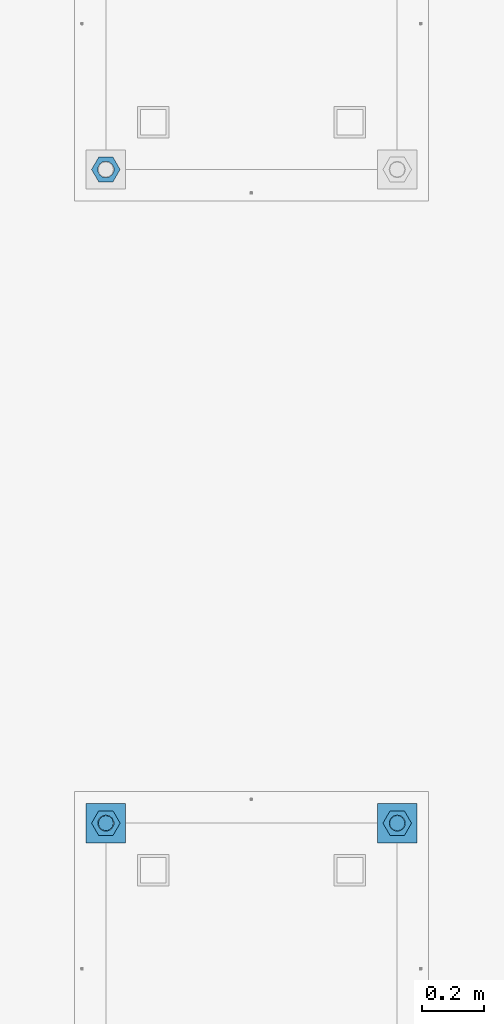
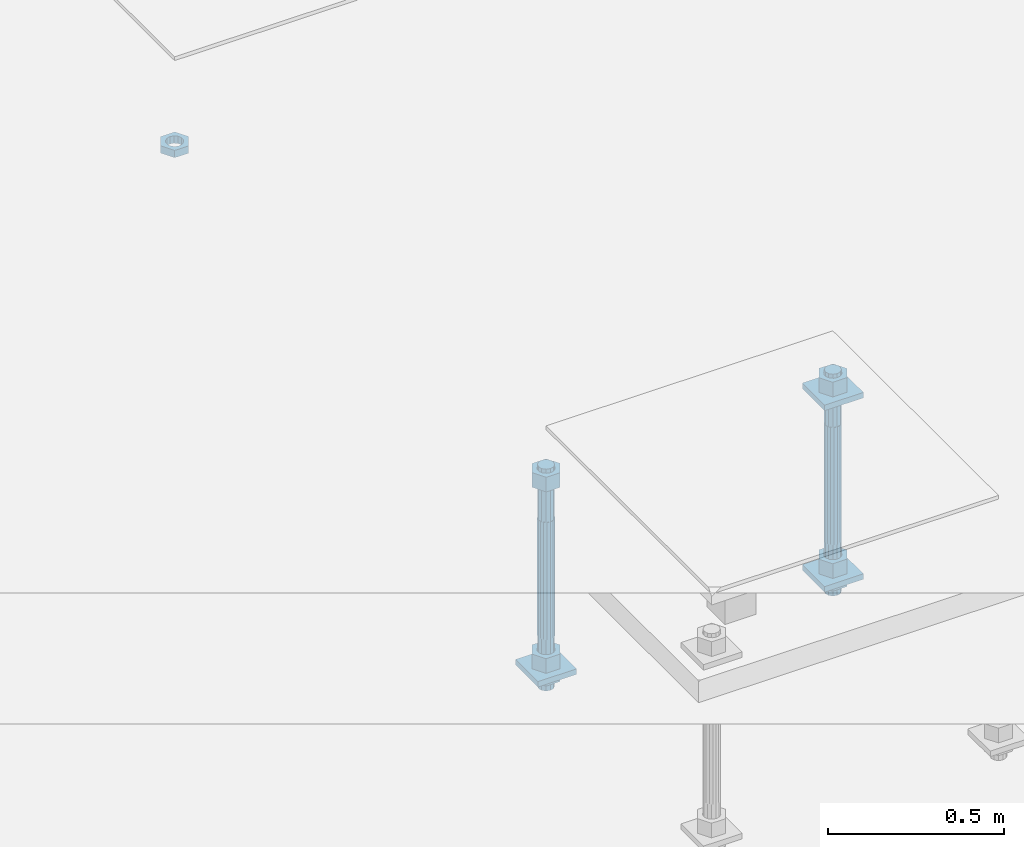
# One storey, part 2576 of 3843: 12 beams, 2 elements without a shape of their own.
"""IFC2X3 building model written with IfcOpenShell, lengths in millimetres."""

from ifc_helpers import new_model, si_unit, frame, origin_with_axes, place, context, subcontext, project, spatial, faceted_brep, material, type_object, element, aggregate, save


model = new_model("IFC2X3")

# Units and contexts
model_context = context("Model", 3, precision=1e-05, world=origin_with_axes())
body_context = subcontext(model_context, "Body", "Model", "MODEL_VIEW")
ifc_project = project(units=[si_unit("LENGTHUNIT", "METRE", prefix="MILLI"), si_unit("AREAUNIT", "SQUARE_METRE"), si_unit("VOLUMEUNIT", "CUBIC_METRE"), si_unit("MASSUNIT", "GRAM", prefix="KILO"), si_unit("TIMEUNIT", "SECOND"), si_unit("PLANEANGLEUNIT", "RADIAN"), si_unit("SOLIDANGLEUNIT", "STERADIAN"), si_unit("THERMODYNAMICTEMPERATUREUNIT", "DEGREE_CELSIUS"), si_unit("LUMINOUSINTENSITYUNIT", "LUMEN")], contexts=[model_context])

# Site, building, storey
site_placement = place(None, origin_with_axes())
site = spatial("IfcSite", under=ifc_project, at=site_placement, CompositionType="ELEMENT")
building_placement = place(site_placement, origin_with_axes())
building = spatial("IfcBuilding", under=site, at=building_placement, Name="Undefined", CompositionType="ELEMENT")
storey_placement = place(building_placement, origin_with_axes())
storey = spatial("IfcBuildingStorey", under=building, at=storey_placement, Name="Undefined", CompositionType="ELEMENT", Elevation=0.0)

# Assembly, beams
assembly_1_placement = place(storey_placement, origin_with_axes())
assembly_1 = element("IfcElementAssembly", 1, at=assembly_1_placement, inside=storey, Name="TEMPLATE", AssemblyPlace="NOTDEFINED", PredefinedType="RIGID_FRAME")
ifc_material_1 = material(Name="STEEL/A36")
beam_type_1 = type_object("IfcBeamType", PredefinedType="NOTDEFINED")
beam_1_placement = place(assembly_1_placement, frame((109423.2, 7861.30000152589, 29873.575), z_axis=(1.0, 0.0, 0.0), x_axis=(0.0, 1.0, 0.0)))
beam_1 = element("IfcBeam", 2, at=beam_1_placement, type_object=beam_type_1, material=ifc_material_1, Name="WASHER_PLATE", context=body_context, shape_type="Brep", body=[
    faceted_brep([(0.0, 9.52500000000146, -63.5), (0.0, 9.52500000000146, 63.5), (127.0, 9.52500000000146, 63.5), (127.0, 9.52500000000146, -63.5), (0.0, -9.52500000000146, 63.5), (127.0, -9.52500000000146, 63.5), (0.0, -9.52500000000146, -63.5), (127.0, -9.52500000000146, -63.5)], [[[0, 1, 2, 3]], [[1, 4, 5, 2]], [[4, 6, 7, 5]], [[6, 0, 3, 7]], [[5, 7, 3, 2]], [[6, 4, 1, 0]]]),
])
beam_2_placement = place(assembly_1_placement, frame((108483.4, 7861.30000152588, 29244.925), z_axis=(1.0, 0.0, 0.0), x_axis=(0.0, 1.0, 0.0)))
beam_2 = element("IfcBeam", 3, at=beam_2_placement, type_object=beam_type_1, material=ifc_material_1, Name="WASHER_PLATE", context=body_context, shape_type="Brep", body=[
    faceted_brep([(0.0, 9.52500000000146, -63.5), (0.0, 9.52500000000146, 63.5), (127.0, 9.52500000000146, 63.5), (127.0, 9.52500000000146, -63.5), (0.0, -9.52500000000146, 63.5), (127.0, -9.52500000000146, 63.5), (0.0, -9.52500000000146, -63.5), (127.0, -9.52500000000146, -63.5)], [[[0, 1, 2, 3]], [[1, 4, 5, 2]], [[4, 6, 7, 5]], [[6, 0, 3, 7]], [[5, 7, 3, 2]], [[6, 4, 1, 0]]]),
])
beam_3_placement = place(assembly_1_placement, frame((109423.2, 7861.30000152588, 29244.925), z_axis=(1.0, 0.0, 0.0), x_axis=(0.0, 1.0, 0.0)))
beam_3 = element("IfcBeam", 4, at=beam_3_placement, type_object=beam_type_1, material=ifc_material_1, Name="WASHER_PLATE", context=body_context, shape_type="Brep", body=[
    faceted_brep([(0.0, 9.52500000000146, -63.5), (0.0, 9.52500000000146, 63.5), (127.0, 9.52500000000146, 63.5), (127.0, 9.52500000000146, -63.5), (0.0, -9.52500000000146, 63.5), (127.0, -9.52500000000146, 63.5), (0.0, -9.52500000000146, -63.5), (127.0, -9.52500000000146, -63.5)], [[[0, 1, 2, 3]], [[1, 4, 5, 2]], [[4, 6, 7, 5]], [[6, 0, 3, 7]], [[5, 7, 3, 2]], [[6, 4, 1, 0]]]),
])

# Assembly, beam
assembly_2_placement = place(storey_placement, origin_with_axes())
assembly_2 = element("IfcElementAssembly", 5, at=assembly_2_placement, inside=storey, Name="TEMPLATE", AssemblyPlace="NOTDEFINED", PredefinedType="RIGID_FRAME")
beam_type_2 = type_object("IfcBeamType", Name="2_HALF_NUT", PredefinedType="NOTDEFINED")
beam_4_placement = place(assembly_2_placement, frame((108483.4, 10033.0000015259, 29787.85), z_axis=(0.0, -1.0, 0.0), x_axis=(0.0, 0.0, -1.0)))
beam_4 = element("IfcBeam", 6, at=beam_4_placement, type_object=beam_type_2, material=ifc_material_1, Name="NUT", ObjectType="2_HALF_NUT", context=body_context, shape_type="Brep", body=[
    faceted_brep([(0.0, -46.0369987487793, 0.0), (0.0, -23.0184993743896, -39.869213104248), (25.4000000000015, -23.0184993743896, -39.869213104248), (25.4000000000015, -46.0369987487793, 0.0), (0.0, 23.0184993743896, -39.869213104248), (25.4000000000015, 23.0184993743896, -39.869213104248), (0.0, 46.0369987487793, 0.0), (25.4000000000015, 46.0369987487793, 0.0), (0.0, 23.0184993743896, 39.869213104248), (25.4000000000015, 23.0184993743896, 39.869213104248), (0.0, -23.0184993743896, 39.869213104248), (25.4000000000015, -23.0184993743896, 39.869213104248), (0.0, 0.0, 26.1940002441406), (0.0, 11.3650617044477, 23.5999013092805), (25.4000000000015, 11.3650617044477, 23.5999013092805), (25.4000000000015, 0.0, 26.1940002441406), (0.0, 20.4791109456419, 16.3316083006721), (25.4000000000015, 20.4791109456419, 16.3316083006721), (0.0, 25.5370200498292, 5.82867859874386), (25.4000000000015, 25.5370200498292, 5.82867859874386), (0.0, 25.5370200498292, -5.82867859874386), (25.4000000000015, 25.5370200498292, -5.82867859874386), (0.0, 20.4791109456419, -16.3316083006721), (25.4000000000015, 20.4791109456419, -16.3316083006721), (0.0, 11.3650617044477, -23.5999013092805), (25.4000000000015, 11.3650617044477, -23.5999013092805), (0.0, 0.0, -26.1940002441406), (25.4000000000015, 0.0, -26.1940002441406), (0.0, -11.3650617044477, -23.5999013092805), (25.4000000000015, -11.3650617044477, -23.5999013092805), (0.0, -20.4791109456419, -16.3316083006721), (25.4000000000015, -20.4791109456419, -16.3316083006721), (0.0, -25.5370200498292, -5.82867859874386), (25.4000000000015, -25.5370200498292, -5.82867859874386), (0.0, -25.5370200498292, 5.82867859874386), (25.4000000000015, -25.5370200498292, 5.82867859874386), (0.0, -20.4791109456419, 16.3316083006721), (25.4000000000015, -20.4791109456419, 16.3316083006721), (0.0, -11.3650617044477, 23.5999013092805), (25.4000000000015, -11.3650617044477, 23.5999013092805)], [[[0, 1, 2, 3]], [[1, 4, 5, 2]], [[4, 6, 7, 5]], [[6, 8, 9, 7]], [[8, 10, 11, 9]], [[10, 0, 3, 11]], [[12, 13, 14, 15]], [[13, 16, 17, 14]], [[16, 18, 19, 17]], [[18, 20, 21, 19]], [[20, 22, 23, 21]], [[22, 24, 25, 23]], [[24, 26, 27, 25]], [[26, 28, 29, 27]], [[28, 30, 31, 29]], [[30, 32, 33, 31]], [[32, 34, 35, 33]], [[34, 36, 37, 35]], [[36, 38, 39, 37]], [[38, 12, 15, 39]], [[5, 7, 9, 11, 3, 2], [17, 19, 21, 23, 25, 27, 29, 31, 33, 35, 37, 39, 15, 14]], [[10, 8, 6, 4, 1, 0], [38, 36, 34, 32, 30, 28, 26, 24, 22, 20, 18, 16, 13, 12]]]),
])
aggregate(assembly_2, [beam_4])

# Beam
beam_5_placement = place(assembly_1_placement, frame((108483.4, 7924.80000152588, 29235.4), z_axis=(0.0, -1.0, 0.0), x_axis=(0.0, 0.0, -1.0)))
beam_5 = element("IfcBeam", 7, at=beam_5_placement, type_object=beam_type_2, material=ifc_material_1, Name="NUT", ObjectType="2_HALF_NUT", context=body_context, shape_type="Brep", body=[
    faceted_brep([(0.0, -46.0369987487793, 0.0), (0.0, -23.0184993743896, -39.869213104248), (25.4000000000015, -23.0184993743896, -39.869213104248), (25.4000000000015, -46.0369987487793, 0.0), (0.0, 23.0184993743896, -39.869213104248), (25.4000000000015, 23.0184993743896, -39.869213104248), (0.0, 46.0369987487793, 0.0), (25.4000000000015, 46.0369987487793, 0.0), (0.0, 23.0184993743896, 39.869213104248), (25.4000000000015, 23.0184993743896, 39.869213104248), (0.0, -23.0184993743896, 39.869213104248), (25.4000000000015, -23.0184993743896, 39.869213104248), (0.0, 0.0, 26.1940002441406), (0.0, 11.3650617044477, 23.5999013092805), (25.4000000000015, 11.3650617044477, 23.5999013092805), (25.4000000000015, 0.0, 26.1940002441406), (0.0, 20.4791109456419, 16.3316083006721), (25.4000000000015, 20.4791109456419, 16.3316083006721), (0.0, 25.5370200498292, 5.82867859874386), (25.4000000000015, 25.5370200498292, 5.82867859874386), (0.0, 25.5370200498292, -5.82867859874386), (25.4000000000015, 25.5370200498292, -5.82867859874386), (0.0, 20.4791109456419, -16.3316083006721), (25.4000000000015, 20.4791109456419, -16.3316083006721), (0.0, 11.3650617044477, -23.5999013092805), (25.4000000000015, 11.3650617044477, -23.5999013092805), (0.0, 0.0, -26.1940002441406), (25.4000000000015, 0.0, -26.1940002441406), (0.0, -11.3650617044477, -23.5999013092805), (25.4000000000015, -11.3650617044477, -23.5999013092805), (0.0, -20.4791109456419, -16.3316083006721), (25.4000000000015, -20.4791109456419, -16.3316083006721), (0.0, -25.5370200498292, -5.82867859874386), (25.4000000000015, -25.5370200498292, -5.82867859874386), (0.0, -25.5370200498292, 5.82867859874386), (25.4000000000015, -25.5370200498292, 5.82867859874386), (0.0, -20.4791109456419, 16.3316083006721), (25.4000000000015, -20.4791109456419, 16.3316083006721), (0.0, -11.3650617044477, 23.5999013092805), (25.4000000000015, -11.3650617044477, 23.5999013092805)], [[[0, 1, 2, 3]], [[1, 4, 5, 2]], [[4, 6, 7, 5]], [[6, 8, 9, 7]], [[8, 10, 11, 9]], [[10, 0, 3, 11]], [[12, 13, 14, 15]], [[13, 16, 17, 14]], [[16, 18, 19, 17]], [[18, 20, 21, 19]], [[20, 22, 23, 21]], [[22, 24, 25, 23]], [[24, 26, 27, 25]], [[26, 28, 29, 27]], [[28, 30, 31, 29]], [[30, 32, 33, 31]], [[32, 34, 35, 33]], [[34, 36, 37, 35]], [[36, 38, 39, 37]], [[38, 12, 15, 39]], [[5, 7, 9, 11, 3, 2], [17, 19, 21, 23, 25, 27, 29, 31, 33, 35, 37, 39, 15, 14]], [[10, 8, 6, 4, 1, 0], [38, 36, 34, 32, 30, 28, 26, 24, 22, 20, 18, 16, 13, 12]]]),
])

beam_6_placement = place(assembly_1_placement, frame((109423.2, 7924.80000152588, 29235.4), z_axis=(0.0, 1.0, 0.0), x_axis=(0.0, 0.0, -1.0)))
beam_6 = element("IfcBeam", 8, at=beam_6_placement, type_object=beam_type_2, material=ifc_material_1, Name="NUT", ObjectType="2_HALF_NUT", context=body_context, shape_type="Brep", body=[
    faceted_brep([(0.0, -46.0369987487793, 0.0), (0.0, -23.0184993743896, -39.869213104248), (25.4000000000015, -23.0184993743896, -39.869213104248), (25.4000000000015, -46.0369987487793, 0.0), (0.0, 23.0184993743896, -39.869213104248), (25.4000000000015, 23.0184993743896, -39.869213104248), (0.0, 46.0369987487793, 0.0), (25.4000000000015, 46.0369987487793, 0.0), (0.0, 23.0184993743896, 39.869213104248), (25.4000000000015, 23.0184993743896, 39.869213104248), (0.0, -23.0184993743896, 39.869213104248), (25.4000000000015, -23.0184993743896, 39.869213104248), (0.0, 0.0, 26.1940002441406), (0.0, 11.3650617044477, 23.5999013092805), (25.4000000000015, 11.3650617044477, 23.5999013092805), (25.4000000000015, 0.0, 26.1940002441406), (0.0, 20.4791109456419, 16.3316083006721), (25.4000000000015, 20.4791109456419, 16.3316083006721), (0.0, 25.5370200498292, 5.82867859874386), (25.4000000000015, 25.5370200498292, 5.82867859874386), (0.0, 25.5370200498292, -5.82867859874386), (25.4000000000015, 25.5370200498292, -5.82867859874386), (0.0, 20.4791109456419, -16.3316083006721), (25.4000000000015, 20.4791109456419, -16.3316083006721), (0.0, 11.3650617044477, -23.5999013092805), (25.4000000000015, 11.3650617044477, -23.5999013092805), (0.0, 0.0, -26.1940002441406), (25.4000000000015, 0.0, -26.1940002441406), (0.0, -11.3650617044477, -23.5999013092805), (25.4000000000015, -11.3650617044477, -23.5999013092805), (0.0, -20.4791109456419, -16.3316083006721), (25.4000000000015, -20.4791109456419, -16.3316083006721), (0.0, -25.5370200498292, -5.82867859874386), (25.4000000000015, -25.5370200498292, -5.82867859874386), (0.0, -25.5370200498292, 5.82867859874386), (25.4000000000015, -25.5370200498292, 5.82867859874386), (0.0, -20.4791109456419, 16.3316083006721), (25.4000000000015, -20.4791109456419, 16.3316083006721), (0.0, -11.3650617044477, 23.5999013092805), (25.4000000000015, -11.3650617044477, 23.5999013092805)], [[[0, 1, 2, 3]], [[1, 4, 5, 2]], [[4, 6, 7, 5]], [[6, 8, 9, 7]], [[8, 10, 11, 9]], [[10, 0, 3, 11]], [[12, 13, 14, 15]], [[13, 16, 17, 14]], [[16, 18, 19, 17]], [[18, 20, 21, 19]], [[20, 22, 23, 21]], [[22, 24, 25, 23]], [[24, 26, 27, 25]], [[26, 28, 29, 27]], [[28, 30, 31, 29]], [[30, 32, 33, 31]], [[32, 34, 35, 33]], [[34, 36, 37, 35]], [[36, 38, 39, 37]], [[38, 12, 15, 39]], [[5, 7, 9, 11, 3, 2], [17, 19, 21, 23, 25, 27, 29, 31, 33, 35, 37, 39, 15, 14]], [[10, 8, 6, 4, 1, 0], [38, 36, 34, 32, 30, 28, 26, 24, 22, 20, 18, 16, 13, 12]]]),
])

beam_type_3 = type_object("IfcBeamType", Name="2_HEAVY_HEX_NUT", PredefinedType="NOTDEFINED")
beam_7_placement = place(assembly_1_placement, frame((108483.4, 7924.80000152588, 29933.9), z_axis=(0.0, -1.0, 0.0), x_axis=(0.0, 0.0, -1.0)))
beam_7 = element("IfcBeam", 9, at=beam_7_placement, type_object=beam_type_3, material=ifc_material_1, Name="NUT", ObjectType="2_HEAVY_HEX_NUT", context=body_context, shape_type="Brep", body=[
    faceted_brep([(0.0, -46.0369987487793, 0.0), (0.0, -23.0184993743896, -39.869213104248), (50.7999999999993, -23.0184993743896, -39.869213104248), (50.7999999999993, -46.0369987487793, 0.0), (0.0, 23.0184993743896, -39.869213104248), (50.7999999999993, 23.0184993743896, -39.869213104248), (0.0, 46.0369987487793, 0.0), (50.7999999999993, 46.0369987487793, 0.0), (0.0, 23.0184993743896, 39.869213104248), (50.7999999999993, 23.0184993743896, 39.869213104248), (0.0, -23.0184993743896, 39.869213104248), (50.7999999999993, -23.0184993743896, 39.869213104248), (0.0, 0.0, 26.1940002441406), (0.0, 11.3650617044477, 23.5999013092805), (50.7999999999993, 11.3650617044477, 23.5999013092805), (50.7999999999993, 0.0, 26.1940002441406), (0.0, 20.4791109456419, 16.3316083006721), (50.7999999999993, 20.4791109456419, 16.3316083006721), (0.0, 25.5370200498292, 5.82867859874386), (50.7999999999993, 25.5370200498292, 5.82867859874386), (0.0, 25.5370200498292, -5.82867859874386), (50.7999999999993, 25.5370200498292, -5.82867859874386), (0.0, 20.4791109456419, -16.3316083006721), (50.7999999999993, 20.4791109456419, -16.3316083006721), (0.0, 11.3650617044477, -23.5999013092805), (50.7999999999993, 11.3650617044477, -23.5999013092805), (0.0, 0.0, -26.1940002441406), (50.7999999999993, 0.0, -26.1940002441406), (0.0, -11.3650617044477, -23.5999013092805), (50.7999999999993, -11.3650617044477, -23.5999013092805), (0.0, -20.4791109456419, -16.3316083006721), (50.7999999999993, -20.4791109456419, -16.3316083006721), (0.0, -25.5370200498292, -5.82867859874386), (50.7999999999993, -25.5370200498292, -5.82867859874386), (0.0, -25.5370200498292, 5.82867859874386), (50.7999999999993, -25.5370200498292, 5.82867859874386), (0.0, -20.4791109456419, 16.3316083006721), (50.7999999999993, -20.4791109456419, 16.3316083006721), (0.0, -11.3650617044477, 23.5999013092805), (50.7999999999993, -11.3650617044477, 23.5999013092805)], [[[0, 1, 2, 3]], [[1, 4, 5, 2]], [[4, 6, 7, 5]], [[6, 8, 9, 7]], [[8, 10, 11, 9]], [[10, 0, 3, 11]], [[12, 13, 14, 15]], [[13, 16, 17, 14]], [[16, 18, 19, 17]], [[18, 20, 21, 19]], [[20, 22, 23, 21]], [[22, 24, 25, 23]], [[24, 26, 27, 25]], [[26, 28, 29, 27]], [[28, 30, 31, 29]], [[30, 32, 33, 31]], [[32, 34, 35, 33]], [[34, 36, 37, 35]], [[36, 38, 39, 37]], [[38, 12, 15, 39]], [[5, 7, 9, 11, 3, 2], [17, 19, 21, 23, 25, 27, 29, 31, 33, 35, 37, 39, 15, 14]], [[10, 8, 6, 4, 1, 0], [38, 36, 34, 32, 30, 28, 26, 24, 22, 20, 18, 16, 13, 12]]]),
])

beam_8_placement = place(assembly_1_placement, frame((108483.4, 7924.80000152588, 29305.25), z_axis=(0.0, -1.0, 0.0), x_axis=(0.0, 0.0, -1.0)))
beam_8 = element("IfcBeam", 10, at=beam_8_placement, type_object=beam_type_3, material=ifc_material_1, Name="NUT", ObjectType="2_HEAVY_HEX_NUT", context=body_context, shape_type="Brep", body=[
    faceted_brep([(0.0, -46.0369987487793, 0.0), (0.0, -23.0184993743896, -39.869213104248), (50.7999999999993, -23.0184993743896, -39.869213104248), (50.7999999999993, -46.0369987487793, 0.0), (0.0, 23.0184993743896, -39.869213104248), (50.7999999999993, 23.0184993743896, -39.869213104248), (0.0, 46.0369987487793, 0.0), (50.7999999999993, 46.0369987487793, 0.0), (0.0, 23.0184993743896, 39.869213104248), (50.7999999999993, 23.0184993743896, 39.869213104248), (0.0, -23.0184993743896, 39.869213104248), (50.7999999999993, -23.0184993743896, 39.869213104248), (0.0, 0.0, 26.1940002441406), (0.0, 11.3650617044477, 23.5999013092805), (50.7999999999993, 11.3650617044477, 23.5999013092805), (50.7999999999993, 0.0, 26.1940002441406), (0.0, 20.4791109456419, 16.3316083006721), (50.7999999999993, 20.4791109456419, 16.3316083006721), (0.0, 25.5370200498292, 5.82867859874386), (50.7999999999993, 25.5370200498292, 5.82867859874386), (0.0, 25.5370200498292, -5.82867859874386), (50.7999999999993, 25.5370200498292, -5.82867859874386), (0.0, 20.4791109456419, -16.3316083006721), (50.7999999999993, 20.4791109456419, -16.3316083006721), (0.0, 11.3650617044477, -23.5999013092805), (50.7999999999993, 11.3650617044477, -23.5999013092805), (0.0, 0.0, -26.1940002441406), (50.7999999999993, 0.0, -26.1940002441406), (0.0, -11.3650617044477, -23.5999013092805), (50.7999999999993, -11.3650617044477, -23.5999013092805), (0.0, -20.4791109456419, -16.3316083006721), (50.7999999999993, -20.4791109456419, -16.3316083006721), (0.0, -25.5370200498292, -5.82867859874386), (50.7999999999993, -25.5370200498292, -5.82867859874386), (0.0, -25.5370200498292, 5.82867859874386), (50.7999999999993, -25.5370200498292, 5.82867859874386), (0.0, -20.4791109456419, 16.3316083006721), (50.7999999999993, -20.4791109456419, 16.3316083006721), (0.0, -11.3650617044477, 23.5999013092805), (50.7999999999993, -11.3650617044477, 23.5999013092805)], [[[0, 1, 2, 3]], [[1, 4, 5, 2]], [[4, 6, 7, 5]], [[6, 8, 9, 7]], [[8, 10, 11, 9]], [[10, 0, 3, 11]], [[12, 13, 14, 15]], [[13, 16, 17, 14]], [[16, 18, 19, 17]], [[18, 20, 21, 19]], [[20, 22, 23, 21]], [[22, 24, 25, 23]], [[24, 26, 27, 25]], [[26, 28, 29, 27]], [[28, 30, 31, 29]], [[30, 32, 33, 31]], [[32, 34, 35, 33]], [[34, 36, 37, 35]], [[36, 38, 39, 37]], [[38, 12, 15, 39]], [[5, 7, 9, 11, 3, 2], [17, 19, 21, 23, 25, 27, 29, 31, 33, 35, 37, 39, 15, 14]], [[10, 8, 6, 4, 1, 0], [38, 36, 34, 32, 30, 28, 26, 24, 22, 20, 18, 16, 13, 12]]]),
])

beam_9_placement = place(assembly_1_placement, frame((109423.2, 7924.80000152588, 29933.9), z_axis=(0.0, 1.0, 0.0), x_axis=(0.0, 0.0, -1.0)))
beam_9 = element("IfcBeam", 11, at=beam_9_placement, type_object=beam_type_3, material=ifc_material_1, Name="NUT", ObjectType="2_HEAVY_HEX_NUT", context=body_context, shape_type="Brep", body=[
    faceted_brep([(0.0, -46.0369987487793, 0.0), (0.0, -23.0184993743896, -39.869213104248), (50.7999999999993, -23.0184993743896, -39.869213104248), (50.7999999999993, -46.0369987487793, 0.0), (0.0, 23.0184993743896, -39.869213104248), (50.7999999999993, 23.0184993743896, -39.869213104248), (0.0, 46.0369987487793, 0.0), (50.7999999999993, 46.0369987487793, 0.0), (0.0, 23.0184993743896, 39.869213104248), (50.7999999999993, 23.0184993743896, 39.869213104248), (0.0, -23.0184993743896, 39.869213104248), (50.7999999999993, -23.0184993743896, 39.869213104248), (0.0, 0.0, 26.1940002441406), (0.0, 11.3650617044477, 23.5999013092805), (50.7999999999993, 11.3650617044477, 23.5999013092805), (50.7999999999993, 0.0, 26.1940002441406), (0.0, 20.4791109456419, 16.3316083006721), (50.7999999999993, 20.4791109456419, 16.3316083006721), (0.0, 25.5370200498292, 5.82867859874386), (50.7999999999993, 25.5370200498292, 5.82867859874386), (0.0, 25.5370200498292, -5.82867859874386), (50.7999999999993, 25.5370200498292, -5.82867859874386), (0.0, 20.4791109456419, -16.3316083006721), (50.7999999999993, 20.4791109456419, -16.3316083006721), (0.0, 11.3650617044477, -23.5999013092805), (50.7999999999993, 11.3650617044477, -23.5999013092805), (0.0, 0.0, -26.1940002441406), (50.7999999999993, 0.0, -26.1940002441406), (0.0, -11.3650617044477, -23.5999013092805), (50.7999999999993, -11.3650617044477, -23.5999013092805), (0.0, -20.4791109456419, -16.3316083006721), (50.7999999999993, -20.4791109456419, -16.3316083006721), (0.0, -25.5370200498292, -5.82867859874386), (50.7999999999993, -25.5370200498292, -5.82867859874386), (0.0, -25.5370200498292, 5.82867859874386), (50.7999999999993, -25.5370200498292, 5.82867859874386), (0.0, -20.4791109456419, 16.3316083006721), (50.7999999999993, -20.4791109456419, 16.3316083006721), (0.0, -11.3650617044477, 23.5999013092805), (50.7999999999993, -11.3650617044477, 23.5999013092805)], [[[0, 1, 2, 3]], [[1, 4, 5, 2]], [[4, 6, 7, 5]], [[6, 8, 9, 7]], [[8, 10, 11, 9]], [[10, 0, 3, 11]], [[12, 13, 14, 15]], [[13, 16, 17, 14]], [[16, 18, 19, 17]], [[18, 20, 21, 19]], [[20, 22, 23, 21]], [[22, 24, 25, 23]], [[24, 26, 27, 25]], [[26, 28, 29, 27]], [[28, 30, 31, 29]], [[30, 32, 33, 31]], [[32, 34, 35, 33]], [[34, 36, 37, 35]], [[36, 38, 39, 37]], [[38, 12, 15, 39]], [[5, 7, 9, 11, 3, 2], [17, 19, 21, 23, 25, 27, 29, 31, 33, 35, 37, 39, 15, 14]], [[10, 8, 6, 4, 1, 0], [38, 36, 34, 32, 30, 28, 26, 24, 22, 20, 18, 16, 13, 12]]]),
])

beam_10_placement = place(assembly_1_placement, frame((109423.2, 7924.80000152588, 29305.25), z_axis=(0.0, 1.0, 0.0), x_axis=(0.0, 0.0, -1.0)))
beam_10 = element("IfcBeam", 12, at=beam_10_placement, type_object=beam_type_3, material=ifc_material_1, Name="NUT", ObjectType="2_HEAVY_HEX_NUT", context=body_context, shape_type="Brep", body=[
    faceted_brep([(0.0, -46.0369987487793, 0.0), (0.0, -23.0184993743896, -39.869213104248), (50.7999999999993, -23.0184993743896, -39.869213104248), (50.7999999999993, -46.0369987487793, 0.0), (0.0, 23.0184993743896, -39.869213104248), (50.7999999999993, 23.0184993743896, -39.869213104248), (0.0, 46.0369987487793, 0.0), (50.7999999999993, 46.0369987487793, 0.0), (0.0, 23.0184993743896, 39.869213104248), (50.7999999999993, 23.0184993743896, 39.869213104248), (0.0, -23.0184993743896, 39.869213104248), (50.7999999999993, -23.0184993743896, 39.869213104248), (0.0, 0.0, 26.1940002441406), (0.0, 11.3650617044477, 23.5999013092805), (50.7999999999993, 11.3650617044477, 23.5999013092805), (50.7999999999993, 0.0, 26.1940002441406), (0.0, 20.4791109456419, 16.3316083006721), (50.7999999999993, 20.4791109456419, 16.3316083006721), (0.0, 25.5370200498292, 5.82867859874386), (50.7999999999993, 25.5370200498292, 5.82867859874386), (0.0, 25.5370200498292, -5.82867859874386), (50.7999999999993, 25.5370200498292, -5.82867859874386), (0.0, 20.4791109456419, -16.3316083006721), (50.7999999999993, 20.4791109456419, -16.3316083006721), (0.0, 11.3650617044477, -23.5999013092805), (50.7999999999993, 11.3650617044477, -23.5999013092805), (0.0, 0.0, -26.1940002441406), (50.7999999999993, 0.0, -26.1940002441406), (0.0, -11.3650617044477, -23.5999013092805), (50.7999999999993, -11.3650617044477, -23.5999013092805), (0.0, -20.4791109456419, -16.3316083006721), (50.7999999999993, -20.4791109456419, -16.3316083006721), (0.0, -25.5370200498292, -5.82867859874386), (50.7999999999993, -25.5370200498292, -5.82867859874386), (0.0, -25.5370200498292, 5.82867859874386), (50.7999999999993, -25.5370200498292, 5.82867859874386), (0.0, -20.4791109456419, 16.3316083006721), (50.7999999999993, -20.4791109456419, 16.3316083006721), (0.0, -11.3650617044477, 23.5999013092805), (50.7999999999993, -11.3650617044477, 23.5999013092805)], [[[0, 1, 2, 3]], [[1, 4, 5, 2]], [[4, 6, 7, 5]], [[6, 8, 9, 7]], [[8, 10, 11, 9]], [[10, 0, 3, 11]], [[12, 13, 14, 15]], [[13, 16, 17, 14]], [[16, 18, 19, 17]], [[18, 20, 21, 19]], [[20, 22, 23, 21]], [[22, 24, 25, 23]], [[24, 26, 27, 25]], [[26, 28, 29, 27]], [[28, 30, 31, 29]], [[30, 32, 33, 31]], [[32, 34, 35, 33]], [[34, 36, 37, 35]], [[36, 38, 39, 37]], [[38, 12, 15, 39]], [[5, 7, 9, 11, 3, 2], [17, 19, 21, 23, 25, 27, 29, 31, 33, 35, 37, 39, 15, 14]], [[10, 8, 6, 4, 1, 0], [38, 36, 34, 32, 30, 28, 26, 24, 22, 20, 18, 16, 13, 12]]]),
])

ifc_material_2 = material()
beam_type_4 = type_object("IfcBeamType", PredefinedType="NOTDEFINED")
beam_11_placement = place(assembly_1_placement, frame((108483.4, 7924.80000152588, 29762.45), z_axis=(0.0, -1.0, 0.0), x_axis=(0.0, 0.0, -1.0)))
beam_11 = element("IfcBeam", 13, at=beam_11_placement, type_object=beam_type_4, material=ifc_material_2, Name="ANCHOR_ROD", context=body_context, shape_type="Brep", body=[
    faceted_brep([(-184.150000000001, -21.217622392709, 12.25), (-184.150000000001, -12.2499999999854, 21.2176223927163), (-184.150000000001, 1.45519152283669e-11, 24.5), (-184.150000000001, 12.2500000000146, 21.2176223927163), (-184.150000000001, 21.2176223927381, 12.25), (-184.150000000001, 24.5000000000146, 0.0), (-184.150000000001, 21.2176223927381, -12.25), (-184.150000000001, 12.2500000000146, -21.2176223927163), (-184.150000000001, 1.45519152283669e-11, -24.5), (-184.150000000001, -12.2499999999854, -21.2176223927163), (-184.150000000001, -21.217622392709, -12.25), (-184.150000000001, -24.4999999999854, 0.0), (0.0, 24.5000000000146, 0.0), (0.0, 21.2176223927381, -12.25), (0.0, 12.2500000000146, -21.2176223927163), (0.0, 1.45519152283669e-11, -24.5), (0.0, -12.2499999999854, -21.2176223927163), (0.0, -21.217622392709, -12.25), (0.0, -24.4999999999854, 0.0), (0.0, -21.217622392709, 12.25), (0.0, -12.2499999999854, 21.2176223927163), (0.0, 1.45519152283669e-11, 24.5), (0.0, 12.2500000000146, 21.2176223927163), (0.0, 21.2176223927381, 12.25), (0.0, -23.4665401257807, 9.72015918207035), (0.0, -17.9605122421344, 17.9605122421417), (0.0, -9.72015918207762, 23.466540125788), (0.0, 0.0, 25.4000000000015), (0.0, 9.72015918207762, 23.466540125788), (0.0, 17.9605122421344, 17.9605122421417), (0.0, 23.4665401257807, 9.72015918207035), (0.0, 25.3999996185303, 0.0), (0.0, 23.4665401257807, -9.72015918207035), (0.0, 17.9605122421344, -17.9605122421417), (0.0, 9.72015918207762, -23.466540125788), (0.0, 0.0, -25.4000000000015), (0.0, -9.72015918207762, -23.466540125788), (0.0, -17.9605122421344, -17.9605122421417), (0.0, -23.4665401257807, -9.72015918207035), (0.0, -25.3999996185303, 0.0), (406.399999999998, -25.3999999999942, 0.0), (406.399999999998, -23.4665401257807, 9.72015918207035), (406.399999999998, -17.9605122421344, 17.9605122421417), (406.399999999998, -9.72015918207762, 23.466540125788), (406.399999999998, 0.0, 25.4000000000015), (406.399999999998, 9.72015918207762, 23.466540125788), (406.399999999998, 17.9605122421344, 17.9605122421417), (406.399999999998, 23.4665401257807, 9.72015918207035), (406.399999999998, 25.3999999999942, 0.0), (406.399999999998, 23.4665401257807, -9.72015918207035), (406.399999999998, 17.9605122421344, -17.9605122421417), (406.399999999998, 9.72015918207762, -23.466540125788), (406.399999999998, 0.0, -25.4000000000015), (406.399999999998, -9.72015918207762, -23.466540125788), (406.399999999998, -17.9605122421344, -17.9605122421417), (406.399999999998, -23.4665401257807, -9.72015918207035), (406.399999999998, -12.2499999999854, 21.2176223927163), (406.399999999998, 1.45519152283669e-11, 24.5), (406.399999999998, 12.2500000000146, 21.2176223927163), (406.399999999998, 21.2176223927381, 12.25), (406.399999999998, 24.5000000000146, 0.0), (406.399999999998, 21.2176223927381, -12.25), (406.399999999998, 12.2500000000146, -21.2176223927163), (406.399999999998, 1.45519152283669e-11, -24.5), (406.399999999998, -12.2499999999854, -21.2176223927163), (406.399999999998, -21.217622392709, -12.25), (406.399999999998, -24.4999999999854, 0.0), (406.399999999998, -21.217622392709, 12.25), (584.200000000001, -12.2499999999854, -21.2176223927163), (584.200000000001, 1.45519152283669e-11, -24.5), (584.200000000001, 12.2500000000146, -21.2176223927163), (584.200000000001, 21.2176223927381, -12.25), (584.200000000001, 24.5000000000146, 0.0), (584.200000000001, 21.2176223927381, 12.25), (584.200000000001, 12.2500000000146, 21.2176223927163), (584.200000000001, 1.45519152283669e-11, 24.5), (584.200000000001, -12.2499999999854, 21.2176223927163), (584.200000000001, -21.217622392709, 12.25), (584.200000000001, -24.4999999999854, 0.0), (584.200000000001, -21.217622392709, -12.25)], [[[0, 1, 2, 3, 4, 5, 6, 7, 8, 9, 10, 11]], [[6, 5, 12, 13]], [[7, 6, 13, 14]], [[8, 7, 14, 15]], [[9, 8, 15, 16]], [[10, 9, 16, 17]], [[11, 10, 17, 18]], [[0, 11, 18, 19]], [[1, 0, 19, 20]], [[2, 1, 20, 21]], [[3, 2, 21, 22]], [[4, 3, 22, 23]], [[5, 4, 23, 12]], [[24, 25, 26, 27, 28, 29, 30, 31, 32, 33, 34, 35, 36, 37, 38, 39], [22, 21, 20, 19, 18, 17, 16, 15, 14, 13, 12, 23]], [[24, 39, 40, 41]], [[25, 24, 41, 42]], [[26, 25, 42, 43]], [[27, 26, 43, 44]], [[28, 27, 44, 45]], [[29, 28, 45, 46]], [[30, 29, 46, 47]], [[31, 30, 47, 48]], [[32, 31, 48, 49]], [[33, 32, 49, 50]], [[34, 33, 50, 51]], [[35, 34, 51, 52]], [[36, 35, 52, 53]], [[37, 36, 53, 54]], [[38, 37, 54, 55]], [[39, 38, 55, 40]], [[54, 53, 52, 51, 50, 49, 48, 47, 46, 45, 44, 43, 42, 41, 40, 55], [56, 57, 58, 59, 60, 61, 62, 63, 64, 65, 66, 67]], [[68, 69, 70, 71, 72, 73, 74, 75, 76, 77, 78, 79]], [[76, 75, 57, 56]], [[77, 76, 56, 67]], [[78, 77, 67, 66]], [[79, 78, 66, 65]], [[68, 79, 65, 64]], [[69, 68, 64, 63]], [[70, 69, 63, 62]], [[71, 70, 62, 61]], [[72, 71, 61, 60]], [[73, 72, 60, 59]], [[74, 73, 59, 58]], [[75, 74, 58, 57]]]),
])

beam_12_placement = place(assembly_1_placement, frame((109423.2, 7924.80000152588, 29762.45), z_axis=(0.0, 1.0, 0.0), x_axis=(0.0, 0.0, -1.0)))
beam_12 = element("IfcBeam", 14, at=beam_12_placement, type_object=beam_type_4, material=ifc_material_2, Name="ANCHOR_ROD", context=body_context, shape_type="Brep", body=[
    faceted_brep([(-184.150000000001, -21.217622392709, 12.25), (-184.150000000001, -12.2499999999854, 21.2176223927163), (-184.150000000001, 1.45519152283669e-11, 24.5), (-184.150000000001, 12.2500000000146, 21.2176223927163), (-184.150000000001, 21.2176223927381, 12.25), (-184.150000000001, 24.5000000000146, 0.0), (-184.150000000001, 21.2176223927381, -12.25), (-184.150000000001, 12.2500000000146, -21.2176223927163), (-184.150000000001, 1.45519152283669e-11, -24.5), (-184.150000000001, -12.2499999999854, -21.2176223927163), (-184.150000000001, -21.217622392709, -12.25), (-184.150000000001, -24.4999999999854, 0.0), (0.0, 24.5000000000146, 0.0), (0.0, 21.2176223927381, -12.25), (0.0, 12.2500000000146, -21.2176223927163), (0.0, 1.45519152283669e-11, -24.5), (0.0, -12.2499999999854, -21.2176223927163), (0.0, -21.217622392709, -12.25), (0.0, -24.4999999999854, 0.0), (0.0, -21.217622392709, 12.25), (0.0, -12.2499999999854, 21.2176223927163), (0.0, 1.45519152283669e-11, 24.5), (0.0, 12.2500000000146, 21.2176223927163), (0.0, 21.2176223927381, 12.25), (0.0, -23.4665401257807, 9.72015918207035), (0.0, -17.9605122421344, 17.9605122421417), (0.0, -9.72015918207762, 23.466540125788), (0.0, 0.0, 25.4000000000015), (0.0, 9.72015918207762, 23.466540125788), (0.0, 17.9605122421344, 17.9605122421417), (0.0, 23.4665401257807, 9.72015918207035), (0.0, 25.3999996185303, 0.0), (0.0, 23.4665401257807, -9.72015918207035), (0.0, 17.9605122421344, -17.9605122421417), (0.0, 9.72015918207762, -23.466540125788), (0.0, 0.0, -25.4000000000015), (0.0, -9.72015918207762, -23.466540125788), (0.0, -17.9605122421344, -17.9605122421417), (0.0, -23.4665401257807, -9.72015918207035), (0.0, -25.3999996185303, 0.0), (406.399999999998, -25.3999999999942, 0.0), (406.399999999998, -23.4665401257807, 9.72015918207035), (406.399999999998, -17.9605122421344, 17.9605122421417), (406.399999999998, -9.72015918207762, 23.466540125788), (406.399999999998, 0.0, 25.4000000000015), (406.399999999998, 9.72015918207762, 23.466540125788), (406.399999999998, 17.9605122421344, 17.9605122421417), (406.399999999998, 23.4665401257807, 9.72015918207035), (406.399999999998, 25.3999999999942, 0.0), (406.399999999998, 23.4665401257807, -9.72015918207035), (406.399999999998, 17.9605122421344, -17.9605122421417), (406.399999999998, 9.72015918207762, -23.466540125788), (406.399999999998, 0.0, -25.4000000000015), (406.399999999998, -9.72015918207762, -23.466540125788), (406.399999999998, -17.9605122421344, -17.9605122421417), (406.399999999998, -23.4665401257807, -9.72015918207035), (406.399999999998, -12.2499999999854, 21.2176223927163), (406.399999999998, 1.45519152283669e-11, 24.5), (406.399999999998, 12.2500000000146, 21.2176223927163), (406.399999999998, 21.2176223927381, 12.25), (406.399999999998, 24.5000000000146, 0.0), (406.399999999998, 21.2176223927381, -12.25), (406.399999999998, 12.2500000000146, -21.2176223927163), (406.399999999998, 1.45519152283669e-11, -24.5), (406.399999999998, -12.2499999999854, -21.2176223927163), (406.399999999998, -21.217622392709, -12.25), (406.399999999998, -24.4999999999854, 0.0), (406.399999999998, -21.217622392709, 12.25), (584.200000000001, -12.2499999999854, -21.2176223927163), (584.200000000001, 1.45519152283669e-11, -24.5), (584.200000000001, 12.2500000000146, -21.2176223927163), (584.200000000001, 21.2176223927381, -12.25), (584.200000000001, 24.5000000000146, 0.0), (584.200000000001, 21.2176223927381, 12.25), (584.200000000001, 12.2500000000146, 21.2176223927163), (584.200000000001, 1.45519152283669e-11, 24.5), (584.200000000001, -12.2499999999854, 21.2176223927163), (584.200000000001, -21.217622392709, 12.25), (584.200000000001, -24.4999999999854, 0.0), (584.200000000001, -21.217622392709, -12.25)], [[[0, 1, 2, 3, 4, 5, 6, 7, 8, 9, 10, 11]], [[6, 5, 12, 13]], [[7, 6, 13, 14]], [[8, 7, 14, 15]], [[9, 8, 15, 16]], [[10, 9, 16, 17]], [[11, 10, 17, 18]], [[0, 11, 18, 19]], [[1, 0, 19, 20]], [[2, 1, 20, 21]], [[3, 2, 21, 22]], [[4, 3, 22, 23]], [[5, 4, 23, 12]], [[24, 25, 26, 27, 28, 29, 30, 31, 32, 33, 34, 35, 36, 37, 38, 39], [22, 21, 20, 19, 18, 17, 16, 15, 14, 13, 12, 23]], [[24, 39, 40, 41]], [[25, 24, 41, 42]], [[26, 25, 42, 43]], [[27, 26, 43, 44]], [[28, 27, 44, 45]], [[29, 28, 45, 46]], [[30, 29, 46, 47]], [[31, 30, 47, 48]], [[32, 31, 48, 49]], [[33, 32, 49, 50]], [[34, 33, 50, 51]], [[35, 34, 51, 52]], [[36, 35, 52, 53]], [[37, 36, 53, 54]], [[38, 37, 54, 55]], [[39, 38, 55, 40]], [[54, 53, 52, 51, 50, 49, 48, 47, 46, 45, 44, 43, 42, 41, 40, 55], [56, 57, 58, 59, 60, 61, 62, 63, 64, 65, 66, 67]], [[68, 69, 70, 71, 72, 73, 74, 75, 76, 77, 78, 79]], [[76, 75, 57, 56]], [[77, 76, 56, 67]], [[78, 77, 67, 66]], [[79, 78, 66, 65]], [[68, 79, 65, 64]], [[69, 68, 64, 63]], [[70, 69, 63, 62]], [[71, 70, 62, 61]], [[72, 71, 61, 60]], [[73, 72, 60, 59]], [[74, 73, 59, 58]], [[75, 74, 58, 57]]]),
])

aggregate(assembly_1, [beam_1, beam_7, beam_8, beam_5, beam_2, beam_11, beam_9, beam_10, beam_6, beam_3, beam_12])

save(model, "model.ifc")
